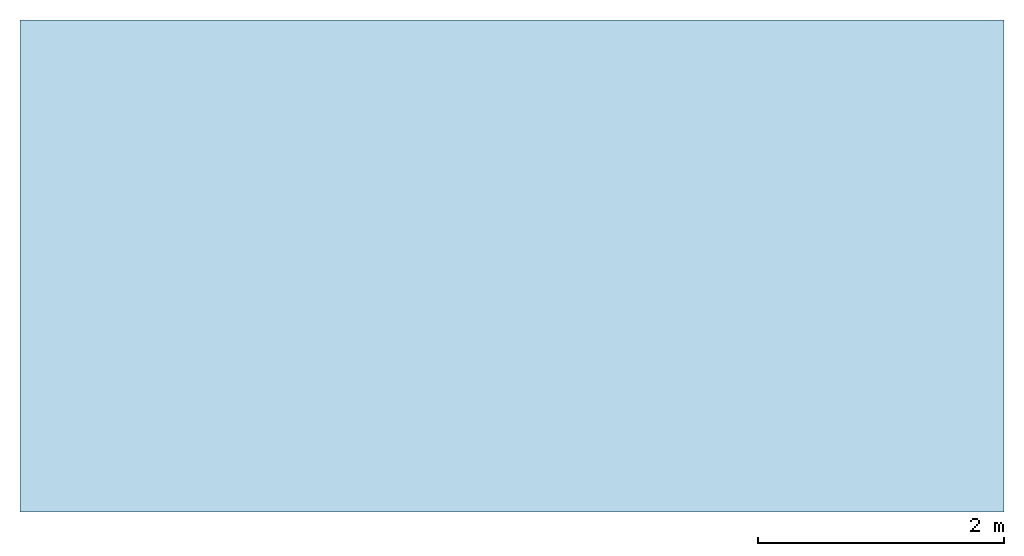
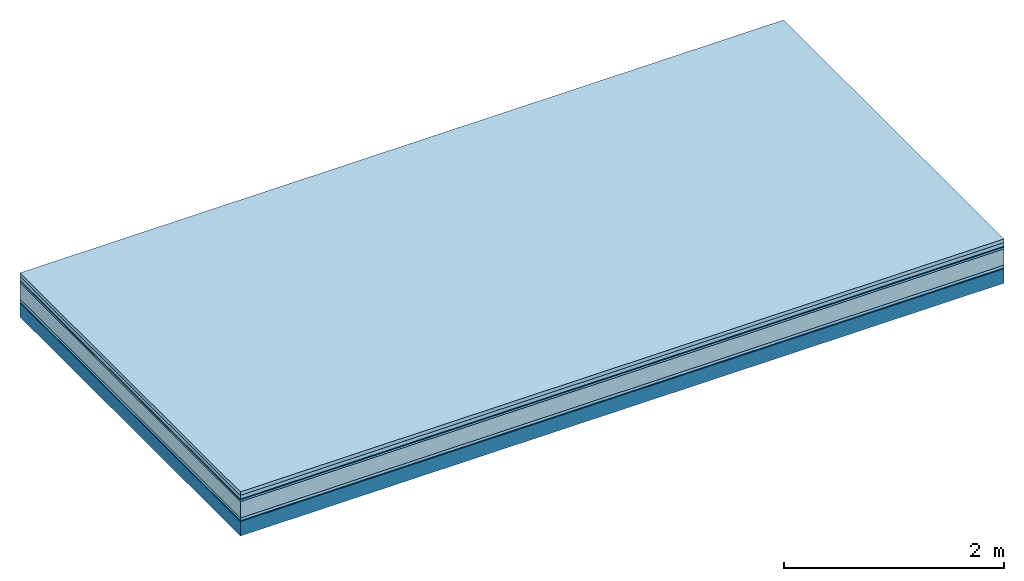
# One storey: 7 plates, 1 member, 1 element without a shape of its own.
"""IFC4 building model written with IfcOpenShell, lengths in metres."""

from ifc_helpers import new_model, si_unit, derived_unit, direction, frame, frame_2d, origin, origin_with_axes, place, context, project, spatial, rectangle, extrude, material, layer, layer_set, type_object, element, aggregate, save


model = new_model("IFC4")

# Units and contexts
plan_context = context("Plan", 3, precision=1e-05, world=origin(), true_north=direction((0.0, 1.0)))
model_context = context("Model", 3, precision=1e-05, world=origin(), true_north=direction((0.0, 1.0)))
ifc_project = project(units=[si_unit("LENGTHUNIT", "METRE"), derived_unit("SOUNDPRESSUREUNIT", [(si_unit("PRESSUREUNIT", "PASCAL", prefix="MICRO"), 0)]), si_unit("ENERGYUNIT", "JOULE", prefix="MEGA"), si_unit("MASSUNIT", "GRAM", prefix="KILO"), derived_unit("THERMALTRANSMITTANCEUNIT", [(si_unit("POWERUNIT", "WATT"), 1), (si_unit("AREAUNIT", "SQUARE_METRE"), -1), (si_unit("THERMODYNAMICTEMPERATUREUNIT", "KELVIN"), -1)]), derived_unit("AREADENSITYUNIT", [(si_unit("MASSUNIT", "GRAM", prefix="KILO"), 1), (si_unit("AREAUNIT", "SQUARE_METRE"), -1)]), derived_unit("USERDEFINED", [(si_unit("ENERGYUNIT", "JOULE", prefix="MEGA"), 1), (si_unit("AREAUNIT", "SQUARE_METRE"), -1)])], contexts=[plan_context, model_context])

# Site, building, storey
site = spatial("IfcSite", under=ifc_project)
building_placement = place(None, origin())
building = spatial("IfcBuilding", under=site, at=building_placement)
storey_placement = place(building_placement, origin())
storey = spatial("IfcBuildingStorey", under=building, at=storey_placement)

# Slab, member, plates
ifc_material_1 = material(Name="Garden plates", Category="02.007")
ifc_layer_1 = layer(ifc_material_1, 0.04, Name="Use and protection layer 3")
ifc_material_2 = material(Name="Gravel 8-16mm", Category="03.011")
ifc_layer_2 = layer(ifc_material_2, 0.04, Name="Use and protection layer 2")
ifc_material_3 = material(Name="Protective layer", Category="09.007")
ifc_layer_3 = layer(ifc_material_3, 0.01, Name="Use and protection layer 1")
ifc_material_4 = material(Name="Bituminous", Category="09.003")
ifc_layer_4 = layer(ifc_material_4, 0.02, Name="Seal")
ifc_material_5 = material(Category="10.006")
ifc_layer_5 = layer(ifc_material_5, 0.18, Name="Exterior insulation layer 2")
ifc_material_6 = material(Name="(034) 25 boards", Category="10.004")
ifc_layer_6 = layer(ifc_material_6, 0.03, Name="Exterior insulation layer 1")
ifc_material_7 = material(Name="Vapor-permeable barrier", Category="09.006")
ifc_layer_7 = layer(ifc_material_7, 0.01, Name="layer / temporary roof")
ifc_material_8 = material(Name="no composite action")
ifc_layer_8 = layer(ifc_material_8, 0.0, Name="Bond")
ifc_layer_9 = layer(None, 0.16, Name="Support")
ifc_layer_set = layer_set([ifc_layer_1, ifc_layer_2, ifc_layer_3, ifc_layer_4, ifc_layer_5, ifc_layer_6, ifc_layer_7, ifc_layer_8, ifc_layer_9])
slab_type = type_object("IfcSlabType", Name="F0062", PredefinedType="NOTDEFINED", material=ifc_layer_set)
slab_placement = place(None, frame((0.0, 0.0, 0.0), z_axis=(0.0, 0.0, -1.0), x_axis=(1.0, 0.0, 0.0)))
slab = element("IfcSlab", 1, at=slab_placement, inside=storey, type_object=slab_type, material=ifc_layer_set, Name="Slab #1")
ifc_material_9 = material(Name="Solid timber panel")
member_placement = place(slab_placement, origin())
member = element("IfcMember", 2, at=member_placement, material=ifc_material_9, Name="Support", context=plan_context, shape_type="SweptSolid", body=[
    extrude(rectangle(XDim=1.0, YDim=0.16, at=frame_2d((0.5, 0.08), x_axis=(1.0, 0.0))), frame((0.0, 4.0, 0.33), z_axis=(0.0, -1.0, 0.0), x_axis=(1.0, 0.0, 0.0)), (0.0, 0.0, 1.0), 4.0),
    extrude(rectangle(XDim=1.0, YDim=0.16, at=frame_2d((0.5, 0.08), x_axis=(1.0, 0.0))), frame((1.0, 4.0, 0.33), z_axis=(0.0, -1.0, 0.0), x_axis=(1.0, 0.0, 0.0)), (0.0, 0.0, 1.0), 4.0),
    extrude(rectangle(XDim=1.0, YDim=0.16, at=frame_2d((0.5, 0.08), x_axis=(1.0, 0.0))), frame((2.0, 4.0, 0.33), z_axis=(0.0, -1.0, 0.0), x_axis=(1.0, 0.0, 0.0)), (0.0, 0.0, 1.0), 4.0),
    extrude(rectangle(XDim=1.0, YDim=0.16, at=frame_2d((0.5, 0.08), x_axis=(1.0, 0.0))), frame((3.0, 4.0, 0.33), z_axis=(0.0, -1.0, 0.0), x_axis=(1.0, 0.0, 0.0)), (0.0, 0.0, 1.0), 4.0),
    extrude(rectangle(XDim=1.0, YDim=0.16, at=frame_2d((0.5, 0.08), x_axis=(1.0, 0.0))), frame((4.0, 4.0, 0.33), z_axis=(0.0, -1.0, 0.0), x_axis=(1.0, 0.0, 0.0)), (0.0, 0.0, 1.0), 4.0),
    extrude(rectangle(XDim=1.0, YDim=0.16, at=frame_2d((0.5, 0.08), x_axis=(1.0, 0.0))), frame((5.0, 4.0, 0.33), z_axis=(0.0, -1.0, 0.0), x_axis=(1.0, 0.0, 0.0)), (0.0, 0.0, 1.0), 4.0),
    extrude(rectangle(XDim=1.0, YDim=0.16, at=frame_2d((0.5, 0.08), x_axis=(1.0, 0.0))), frame((6.0, 4.0, 0.33), z_axis=(0.0, -1.0, 0.0), x_axis=(1.0, 0.0, 0.0)), (0.0, 0.0, 1.0), 4.0),
    extrude(rectangle(XDim=1.0, YDim=0.16, at=frame_2d((0.5, 0.08), x_axis=(1.0, 0.0))), frame((7.0, 4.0, 0.33), z_axis=(0.0, -1.0, 0.0), x_axis=(1.0, 0.0, 0.0)), (0.0, 0.0, 1.0), 4.0),
])
plate_1_placement = place(slab_placement, origin())
plate_1 = element("IfcPlate", 3, at=plate_1_placement, material=ifc_material_1, Name="Use and protection layer 3", context=plan_context, shape_type="SweptSolid", body=[
    extrude(rectangle(XDim=8.0, YDim=4.0, at=frame_2d((4.0, 2.0), x_axis=(1.0, 0.0))), origin_with_axes(), (0.0, 0.0, 1.0), 0.04),
])
plate_2_placement = place(slab_placement, origin())
plate_2 = element("IfcPlate", 4, at=plate_2_placement, material=ifc_material_2, Name="Use and protection layer 2", context=plan_context, shape_type="SweptSolid", body=[
    extrude(rectangle(XDim=8.0, YDim=4.0, at=frame_2d((4.0, 2.0), x_axis=(1.0, 0.0))), frame((0.0, 0.0, 0.04), z_axis=(0.0, 0.0, 1.0), x_axis=(1.0, 0.0, 0.0)), (0.0, 0.0, 1.0), 0.04),
])
plate_3_placement = place(slab_placement, origin())
plate_3 = element("IfcPlate", 5, at=plate_3_placement, material=ifc_material_3, Name="Use and protection layer 1", context=plan_context, shape_type="SweptSolid", body=[
    extrude(rectangle(XDim=8.0, YDim=4.0, at=frame_2d((4.0, 2.0), x_axis=(1.0, 0.0))), frame((0.0, 0.0, 0.08), z_axis=(0.0, 0.0, 1.0), x_axis=(1.0, 0.0, 0.0)), (0.0, 0.0, 1.0), 0.01),
])
plate_4_placement = place(slab_placement, origin())
plate_4 = element("IfcPlate", 6, at=plate_4_placement, material=ifc_material_4, Name="Seal", context=plan_context, shape_type="SweptSolid", body=[
    extrude(rectangle(XDim=8.0, YDim=4.0, at=frame_2d((4.0, 2.0), x_axis=(1.0, 0.0))), frame((0.0, 0.0, 0.09), z_axis=(0.0, 0.0, 1.0), x_axis=(1.0, 0.0, 0.0)), (0.0, 0.0, 1.0), 0.02),
])
plate_5_placement = place(slab_placement, origin())
plate_5 = element("IfcPlate", 7, at=plate_5_placement, material=ifc_material_5, Name="Exterior insulation layer 2", context=plan_context, shape_type="SweptSolid", body=[
    extrude(rectangle(XDim=8.0, YDim=4.0, at=frame_2d((4.0, 2.0), x_axis=(1.0, 0.0))), frame((0.0, 0.0, 0.11), z_axis=(0.0, 0.0, 1.0), x_axis=(1.0, 0.0, 0.0)), (0.0, 0.0, 1.0), 0.18),
])
plate_6_placement = place(slab_placement, origin())
plate_6 = element("IfcPlate", 8, at=plate_6_placement, material=ifc_material_6, Name="Exterior insulation layer 1", context=plan_context, shape_type="SweptSolid", body=[
    extrude(rectangle(XDim=8.0, YDim=4.0, at=frame_2d((4.0, 2.0), x_axis=(1.0, 0.0))), frame((0.0, 0.0, 0.29), z_axis=(0.0, 0.0, 1.0), x_axis=(1.0, 0.0, 0.0)), (0.0, 0.0, 1.0), 0.03),
])
plate_7_placement = place(slab_placement, origin())
plate_7 = element("IfcPlate", 9, at=plate_7_placement, material=ifc_material_7, Name="layer / temporary roof", context=plan_context, shape_type="SweptSolid", body=[
    extrude(rectangle(XDim=8.0, YDim=4.0, at=frame_2d((4.0, 2.0), x_axis=(1.0, 0.0))), frame((0.0, 0.0, 0.32), z_axis=(0.0, 0.0, 1.0), x_axis=(1.0, 0.0, 0.0)), (0.0, 0.0, 1.0), 0.01),
])
aggregate(slab, [plate_1, plate_2, plate_3, plate_4, plate_5, plate_6, plate_7, member])

save(model, "model.ifc")
